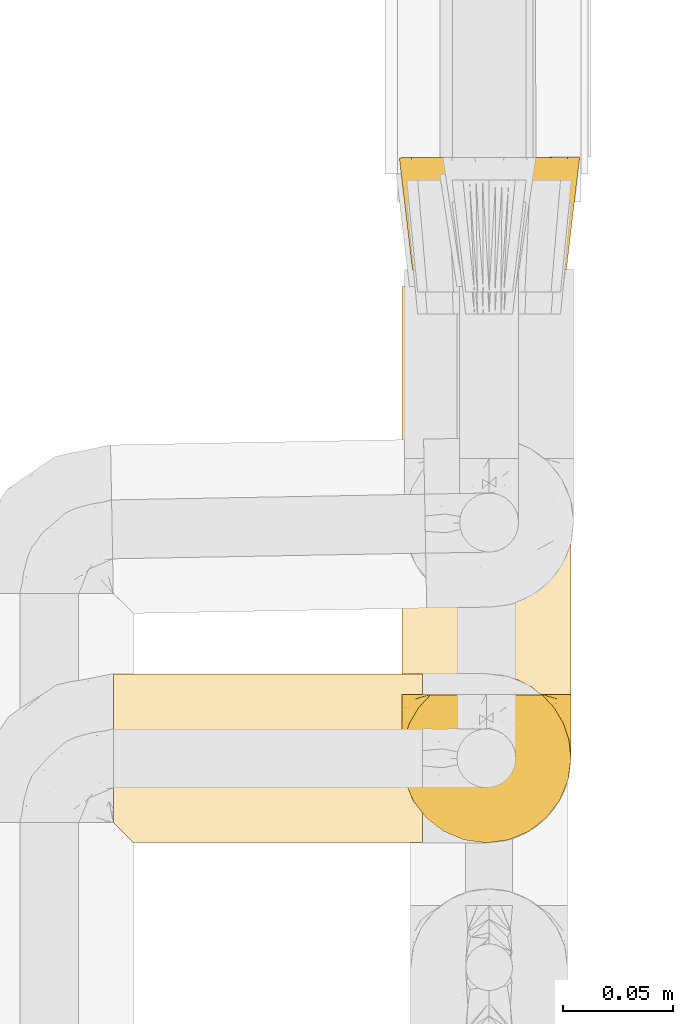
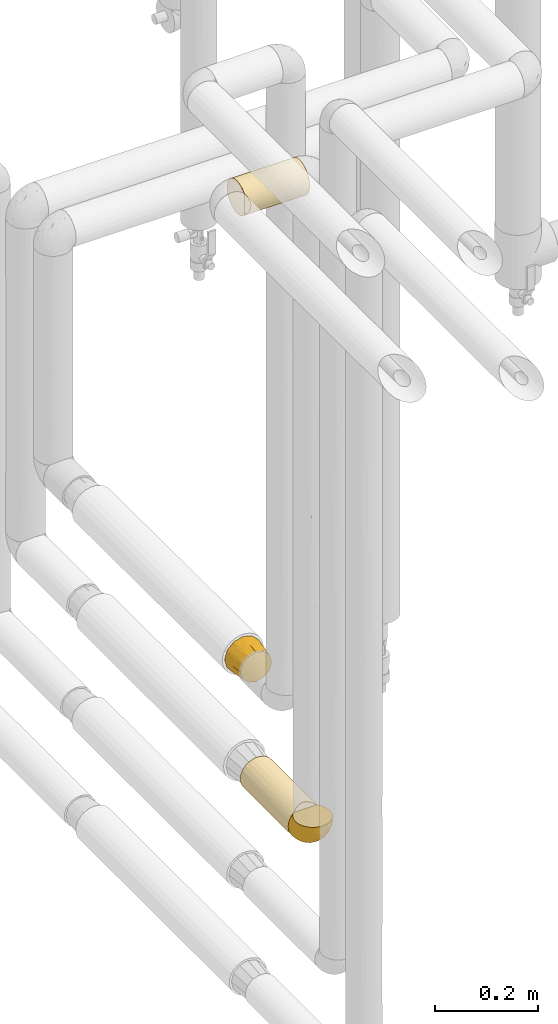
# One storey, part 72 of 827: 4 coverings.
"""IFC2X3 building model written with IfcOpenShell, lengths in millimetres."""

from ifc_helpers import new_model, entity, si_unit, converted_unit, derived_unit, direction, frame, origin, place, context, subcontext, project, spatial, faceted_brep, element, save


model = new_model("IFC2X3")

# Units and contexts
model_context = context("Model", 3, precision=0.01, world=origin(), true_north=direction((6.12303176911189e-17, 1.0)))
body_context = subcontext(model_context, "Body", "Model", "MODEL_VIEW")
ifc_project = project(units=[si_unit("LENGTHUNIT", "METRE", prefix="MILLI"), si_unit("AREAUNIT", "SQUARE_METRE"), si_unit("VOLUMEUNIT", "CUBIC_METRE"), converted_unit("PLANEANGLEUNIT", "DEGREE", entity("IfcRatioMeasure", 0.0174532925199433), si_unit("PLANEANGLEUNIT", "RADIAN"), dimensions=[0, 0, 0, 0, 0, 0, 0]), si_unit("MASSUNIT", "GRAM", prefix="KILO"), derived_unit("MASSDENSITYUNIT", [(si_unit("MASSUNIT", "GRAM", prefix="KILO"), 1), (si_unit("LENGTHUNIT", "METRE"), -3)]), derived_unit("MOMENTOFINERTIAUNIT", [(si_unit("LENGTHUNIT", "METRE"), 4)]), si_unit("TIMEUNIT", "SECOND"), si_unit("FREQUENCYUNIT", "HERTZ"), si_unit("THERMODYNAMICTEMPERATUREUNIT", "DEGREE_CELSIUS"), derived_unit("THERMALTRANSMITTANCEUNIT", [(si_unit("MASSUNIT", "GRAM", prefix="KILO"), 1), (si_unit("THERMODYNAMICTEMPERATUREUNIT", "KELVIN"), -1), (si_unit("TIMEUNIT", "SECOND"), -3)]), derived_unit("VOLUMETRICFLOWRATEUNIT", [(si_unit("LENGTHUNIT", "METRE"), 3), (si_unit("TIMEUNIT", "SECOND"), -1)]), derived_unit("MASSFLOWRATEUNIT", [(si_unit("MASSUNIT", "GRAM", prefix="KILO"), 1), (si_unit("TIMEUNIT", "SECOND"), -1)]), derived_unit("ROTATIONALFREQUENCYUNIT", [(si_unit("TIMEUNIT", "SECOND"), -1)]), si_unit("ELECTRICCURRENTUNIT", "AMPERE"), si_unit("ELECTRICVOLTAGEUNIT", "VOLT"), si_unit("POWERUNIT", "WATT"), si_unit("FORCEUNIT", "NEWTON", prefix="KILO"), si_unit("ILLUMINANCEUNIT", "LUX"), si_unit("LUMINOUSFLUXUNIT", "LUMEN"), si_unit("LUMINOUSINTENSITYUNIT", "CANDELA"), derived_unit("USERDEFINED", [(si_unit("MASSUNIT", "GRAM", prefix="KILO"), -1), (si_unit("LENGTHUNIT", "METRE"), -2), (si_unit("TIMEUNIT", "SECOND"), 3), (si_unit("LUMINOUSFLUXUNIT", "LUMEN"), 1)]), derived_unit("LINEARVELOCITYUNIT", [(si_unit("LENGTHUNIT", "METRE"), 1), (si_unit("TIMEUNIT", "SECOND"), -1)]), si_unit("PRESSUREUNIT", "PASCAL"), derived_unit("USERDEFINED", [(si_unit("LENGTHUNIT", "METRE"), -2), (si_unit("MASSUNIT", "GRAM", prefix="KILO"), 1), (si_unit("TIMEUNIT", "SECOND"), -2)]), derived_unit("LINEARFORCEUNIT", [(si_unit("MASSUNIT", "GRAM", prefix="KILO"), 1), (si_unit("LENGTHUNIT", "METRE"), 1), (si_unit("TIMEUNIT", "SECOND"), -2), (si_unit("LENGTHUNIT", "METRE"), -1)]), derived_unit("PLANARFORCEUNIT", [(si_unit("MASSUNIT", "GRAM", prefix="KILO"), 1), (si_unit("LENGTHUNIT", "METRE"), 1), (si_unit("TIMEUNIT", "SECOND"), -2), (si_unit("LENGTHUNIT", "METRE"), -2)])], contexts=[model_context])

# Site, building, storey
site_placement = place(None, origin())
site = spatial("IfcSite", under=ifc_project, at=site_placement, CompositionType="ELEMENT")
building_placement = place(site_placement, origin())
building = spatial("IfcBuilding", under=site, at=building_placement, CompositionType="ELEMENT")
storey_placement = place(building_placement, frame((0.0, 0.0, 28200.0)))
storey = spatial("IfcBuildingStorey", under=building, at=storey_placement, Name="08", CompositionType="ELEMENT", Elevation=28200.0)

# Coverings
covering_1_placement = place(storey_placement, frame((17886.09, 10978.31, 1305.65)))
element("IfcCovering", 1, at=covering_1_placement, inside=storey, Name=":ADSK_", ObjectType=":ADSK_", PredefinedType="INSULATION", context=body_context, shape_type="Brep", body=[
    faceted_brep([(9.95, 0.01, 51.35), (7.61, 0.0, 42.6), (9.95, 0.01, 33.85), (12.3, 0.02, 25.1), (18.7, 0.04, 18.69), (25.11, 0.06, 12.28), (33.86, 0.09, 9.94), (42.61, 0.12, 7.6), (51.36, 0.15, 9.94), (60.11, 0.18, 12.28), (66.51, 0.2, 18.69), (72.92, 0.22, 25.1), (75.26, 0.23, 33.85), (77.61, 0.24, 42.6), (75.26, 0.23, 51.35), (72.92, 0.22, 60.1), (66.51, 0.2, 66.5), (60.11, 0.18, 72.91), (51.36, 0.15, 75.25), (42.61, 0.12, 77.6), (33.86, 0.09, 75.25), (25.11, 0.06, 72.91), (18.7, 0.04, 66.5), (12.3, 0.02, 60.1), (63.09, 51.19, 78.1), (70.6, 51.21, 70.6), (78.1, 51.24, 63.1), (81.4, 51.25, 50.78), (83.59, 51.26, 42.6), (80.85, 51.25, 32.35), (78.1, 51.24, 22.1), (70.6, 51.21, 14.59), (63.09, 51.19, 7.09), (50.78, 51.15, 3.79), (42.6, 51.12, 1.6), (32.35, 51.08, 4.34), (22.1, 51.05, 7.09), (14.59, 51.02, 14.59), (7.09, 51.0, 22.1), (3.79, 50.99, 34.41), (1.6, 50.98, 42.6), (4.34, 50.99, 52.85), (7.09, 51.0, 63.1), (14.59, 51.02, 70.6), (22.1, 51.05, 78.1), (34.41, 51.09, 81.4), (42.6, 51.12, 83.6), (52.84, 51.15, 80.85), (7.49, 25.5, 28.05), (5.46, 24.36, 35.21), (11.28, 25.51, 21.08), (42.6, 23.62, 4.83), (19.47, 25.54, 12.45), (26.23, 25.56, 8.3), (4.84, 23.49, 42.6), (33.16, 25.59, 5.79), (57.14, 25.67, 7.49), (49.99, 24.51, 5.46), (64.11, 25.69, 11.27), (80.37, 23.76, 42.6), (72.75, 25.72, 19.46), (76.89, 25.74, 26.22), (79.41, 25.74, 33.15), (77.71, 25.74, 57.14), (79.74, 24.61, 49.98), (73.93, 25.73, 64.11), (42.6, 23.63, 80.36), (65.73, 25.7, 72.74), (58.97, 25.67, 76.89), (52.05, 25.65, 79.4), (28.06, 25.57, 77.7), (35.21, 24.46, 79.73), (21.09, 25.55, 73.92), (12.45, 25.52, 65.73), (8.31, 25.5, 58.97), (5.79, 25.49, 52.04)], [[[0, 1, 2, 3, 4, 5, 6, 7, 8, 9, 10, 11, 12, 13, 14, 15, 16, 17, 18, 19, 20, 21, 22, 23]], [[24, 25, 26, 27, 28, 29, 30, 31, 32, 33, 34, 35, 36, 37, 38, 39, 40, 41, 42, 43, 44, 45, 46, 47]], [[39, 48, 49]], [[49, 40, 39]], [[48, 39, 38]], [[3, 2, 48]], [[50, 3, 48]], [[48, 2, 49]], [[51, 7, 6]], [[52, 50, 37]], [[50, 48, 38]], [[5, 52, 53]], [[53, 52, 36]], [[37, 36, 52]], [[50, 38, 37]], [[54, 40, 49, 1]], [[52, 4, 50]], [[4, 3, 50]], [[4, 52, 5]], [[55, 6, 53]], [[53, 35, 55]], [[53, 36, 35]], [[1, 49, 2]], [[6, 5, 53]], [[34, 51, 55]], [[34, 55, 35]], [[51, 6, 55]], [[33, 56, 57]], [[57, 34, 33]], [[56, 33, 32]], [[9, 8, 56]], [[58, 9, 56]], [[56, 8, 57]], [[59, 13, 12]], [[60, 58, 31]], [[58, 56, 32]], [[11, 60, 61]], [[61, 60, 30]], [[31, 30, 60]], [[58, 32, 31]], [[51, 34, 57, 7]], [[60, 10, 58]], [[10, 9, 58]], [[10, 60, 11]], [[62, 12, 61]], [[61, 29, 62]], [[61, 30, 29]], [[7, 57, 8]], [[12, 11, 61]], [[28, 59, 62]], [[28, 62, 29]], [[59, 12, 62]], [[27, 63, 64]], [[64, 28, 27]], [[63, 27, 26]], [[15, 14, 63]], [[65, 15, 63]], [[63, 14, 64]], [[66, 19, 18]], [[67, 65, 25]], [[65, 63, 26]], [[17, 67, 68]], [[68, 67, 24]], [[25, 24, 67]], [[65, 26, 25]], [[59, 28, 64, 13]], [[67, 16, 65]], [[16, 15, 65]], [[16, 67, 17]], [[69, 18, 68]], [[68, 47, 69]], [[68, 24, 47]], [[13, 64, 14]], [[18, 17, 68]], [[46, 66, 69]], [[46, 69, 47]], [[66, 18, 69]], [[45, 70, 71]], [[71, 46, 45]], [[70, 45, 44]], [[21, 20, 70]], [[72, 21, 70]], [[70, 20, 71]], [[54, 1, 0]], [[73, 72, 43]], [[72, 70, 44]], [[23, 73, 74]], [[74, 73, 42]], [[43, 42, 73]], [[72, 44, 43]], [[66, 46, 71, 19]], [[73, 22, 72]], [[22, 21, 72]], [[22, 73, 23]], [[75, 0, 74]], [[74, 41, 75]], [[74, 42, 41]], [[19, 71, 20]], [[0, 23, 74]], [[40, 54, 75]], [[40, 75, 41]], [[54, 0, 75]]]),
])
covering_2_placement = place(storey_placement, frame((17887.28, 10782.63, 1062.52)))
element("IfcCovering", 2, at=covering_2_placement, inside=storey, Name=":ADSK_", ObjectType=":ADSK_", PredefinedType="INSULATION", context=body_context, shape_type="Brep", body=[
    faceted_brep([(20.8, 1.6, 6.74), (30.06, 1.6, 2.9), (40.0, 1.6, 1.6), (49.93, 1.6, 2.9), (59.2, 1.6, 6.74), (67.15, 1.6, 12.84), (73.25, 1.6, 20.8), (77.09, 1.6, 30.06), (78.4, 1.6, 40.0), (77.59, 1.6, 47.8), (75.23, 1.6, 55.25), (71.41, 1.6, 62.08), (66.27, 1.6, 68.0), (13.72, 1.6, 68.0), (8.58, 1.6, 62.08), (4.76, 1.6, 55.25), (2.4, 1.6, 47.8), (1.6, 1.6, 40.0), (2.9, 1.6, 30.06), (6.74, 1.6, 20.8), (12.84, 1.6, 12.84), (20.8, 188.22, 6.74), (12.84, 188.22, 12.84), (6.74, 188.22, 20.8), (2.9, 188.22, 30.06), (1.6, 188.22, 40.0), (2.9, 188.22, 49.93), (6.74, 188.22, 59.2), (12.84, 188.22, 67.15), (20.8, 188.22, 73.25), (30.06, 188.22, 77.09), (40.0, 188.22, 78.4), (49.93, 188.22, 77.09), (59.2, 188.22, 73.25), (67.15, 188.22, 67.15), (73.25, 188.22, 59.2), (77.09, 188.22, 49.93), (78.4, 188.22, 40.0), (77.09, 188.22, 30.06), (73.25, 188.22, 20.8), (67.15, 188.22, 12.84), (59.2, 188.22, 6.74), (49.93, 188.22, 2.9), (40.0, 188.22, 1.6), (30.06, 188.22, 2.9), (54.13, 9.3, 75.7), (47.19, 11.32, 77.72), (40.0, 12.0, 78.4), (60.56, 6.02, 72.42), (32.8, 11.32, 77.72), (25.86, 9.3, 75.7), (19.43, 6.02, 72.42)], [[[0, 1, 2, 3, 4, 5, 6, 7, 8, 9, 10, 11, 12, 13, 14, 15, 16, 17, 18, 19, 20]], [[21, 22, 23, 24, 25, 26, 27, 28, 29, 30, 31, 32, 33, 34, 35, 36, 37, 38, 39, 40, 41, 42, 43, 44]], [[24, 23, 19, 18]], [[25, 24, 18, 17]], [[23, 22, 20, 19]], [[1, 0, 21, 44]], [[2, 1, 44, 43]], [[22, 21, 0, 20]], [[3, 2, 43, 42]], [[4, 3, 42, 41]], [[41, 40, 5, 4]], [[7, 6, 39, 38]], [[8, 7, 38, 37]], [[40, 39, 6, 5]], [[9, 37, 36]], [[10, 36, 35]], [[11, 35, 34]], [[8, 37, 9]], [[9, 36, 10]], [[35, 11, 10]], [[34, 12, 11]], [[45, 33, 32]], [[32, 31, 46]], [[47, 46, 31]], [[12, 34, 48]], [[46, 45, 32]], [[48, 33, 45]], [[48, 34, 33]], [[49, 47, 31]], [[49, 31, 30]], [[50, 30, 29]], [[50, 49, 30]], [[28, 13, 51]], [[50, 29, 51]], [[51, 29, 28]], [[14, 28, 27]], [[15, 27, 26]], [[16, 26, 25]], [[14, 27, 15]], [[15, 26, 16]], [[25, 17, 16]], [[28, 14, 13]], [[45, 46, 47, 49, 50, 51, 13, 12, 48]]]),
])
covering_3_placement = place(storey_placement, frame((17887.23, 10716.18, 1062.47)))
element("IfcCovering", 3, at=covering_3_placement, inside=storey, Name=":ADSK_", ObjectType=":ADSK_", PredefinedType="INSULATION", context=body_context, shape_type="Brep", body=[
    faceted_brep([(74.68, 69.15, 23.36), (70.1, 69.15, 16.07), (64.01, 69.15, 9.98), (56.72, 69.15, 5.4), (48.6, 69.15, 2.56), (40.05, 69.15, 1.6), (31.49, 69.15, 2.56), (23.36, 69.15, 5.41), (16.07, 69.15, 9.99), (9.98, 69.15, 16.08), (5.4, 69.15, 23.37), (2.56, 69.15, 31.49), (1.6, 69.15, 40.05), (2.46, 69.15, 48.15), (5.01, 69.15, 55.88), (9.13, 69.15, 62.9), (14.62, 69.15, 68.89), (16.82, 69.15, 68.89), (18.56, 69.15, 68.89), (20.52, 69.15, 68.89), (22.49, 69.15, 68.89), (24.46, 69.15, 68.89), (26.42, 69.15, 68.89), (28.39, 69.15, 68.89), (30.36, 69.15, 68.89), (32.55, 69.15, 68.89), (34.75, 69.15, 68.89), (36.94, 69.15, 68.89), (39.13, 69.15, 68.89), (41.33, 69.15, 68.89), (43.52, 69.15, 68.89), (45.72, 69.15, 68.89), (47.91, 69.15, 68.89), (50.11, 69.15, 68.89), (52.3, 69.15, 68.89), (54.49, 69.15, 68.89), (56.69, 69.15, 68.89), (58.88, 69.15, 68.89), (61.08, 69.15, 68.89), (63.27, 69.15, 68.89), (65.47, 69.15, 68.89), (70.97, 69.15, 62.89), (75.09, 69.15, 55.86), (77.64, 69.15, 48.13), (78.5, 69.15, 40.05), (77.53, 69.15, 31.49), (14.62, 68.89, 69.15), (9.12, 62.89, 69.15), (5.0, 55.87, 69.15), (2.46, 48.14, 69.15), (1.6, 40.05, 69.15), (2.91, 30.09, 69.15), (6.75, 20.82, 69.15), (12.86, 12.86, 69.15), (20.82, 6.75, 69.15), (30.09, 2.91, 69.15), (40.05, 1.6, 69.15), (50.0, 2.91, 69.15), (59.27, 6.75, 69.15), (67.23, 12.86, 69.15), (73.34, 20.82, 69.15), (77.19, 30.09, 69.15), (78.5, 40.05, 69.15), (77.63, 48.14, 69.15), (75.09, 55.87, 69.15), (70.97, 62.89, 69.15), (65.47, 68.89, 69.15), (63.27, 68.89, 69.15), (62.29, 68.89, 69.15), (60.7, 68.89, 69.15), (59.11, 68.89, 69.15), (57.52, 68.89, 69.15), (55.93, 68.89, 69.15), (54.34, 68.89, 69.15), (52.76, 68.89, 69.15), (51.17, 68.89, 69.15), (49.58, 68.89, 69.15), (47.99, 68.89, 69.15), (46.4, 68.89, 69.15), (44.81, 68.89, 69.15), (43.22, 68.89, 69.15), (41.63, 68.89, 69.15), (40.05, 68.89, 69.15), (38.46, 68.89, 69.15), (36.87, 68.89, 69.15), (35.28, 68.89, 69.15), (33.69, 68.89, 69.15), (32.1, 68.89, 69.15), (30.51, 68.89, 69.15), (28.92, 68.89, 69.15), (27.33, 68.89, 69.15), (25.37, 68.89, 69.15), (23.4, 68.89, 69.15), (21.21, 68.89, 69.15), (19.01, 68.89, 69.15), (16.82, 68.89, 69.15), (42.32, 68.97, 68.96), (44.02, 68.96, 68.97), (47.13, 68.97, 68.97), (48.74, 68.97, 68.97), (23.57, 68.98, 68.95), (25.13, 68.97, 68.96), (61.34, 68.96, 68.98), (22.02, 68.96, 68.97), (29.72, 68.96, 68.97), (56.73, 68.96, 68.98), (55.14, 68.96, 68.97), (37.66, 68.96, 68.97), (64.12, 69.0, 68.94), (28.13, 68.96, 68.98), (26.62, 68.96, 68.98), (31.46, 68.97, 68.96), (16.16, 68.96, 68.97), (39.16, 68.96, 68.98), (50.37, 68.96, 68.98), (17.69, 68.97, 68.97), (19.17, 68.97, 68.96), (62.78, 68.97, 68.97), (58.35, 68.96, 68.97), (45.53, 68.96, 68.98), (59.91, 68.97, 68.96), (65.47, 68.97, 68.97), (65.47, 69.02, 68.94), (65.47, 69.08, 68.92), (14.62, 68.97, 68.97), (14.62, 68.94, 69.02), (14.62, 68.92, 69.08), (20.59, 68.96, 68.98), (32.99, 68.96, 68.97), (34.48, 68.95, 68.98), (51.91, 68.96, 68.97), (65.47, 68.92, 69.08), (65.47, 68.94, 69.02), (53.48, 68.98, 68.96), (14.62, 69.08, 68.92), (14.62, 69.02, 68.94), (40.77, 68.96, 68.97), (35.97, 68.97, 68.96), (7.84, 61.33, 67.02), (3.53, 53.1, 63.33), (8.32, 63.33, 64.61), (2.19, 55.53, 51.4), (3.53, 63.33, 53.1), (1.6, 54.6, 43.94), (1.6, 41.99, 61.87), (4.57, 57.07, 61.54), (3.96, 57.95, 57.95), (2.28, 51.56, 56.12), (1.6, 41.58, 63.4), (7.69, 61.7, 65.41), (8.32, 65.0, 63.04), (7.84, 67.02, 61.33), (1.6, 61.87, 41.99), (1.6, 49.27, 49.27), (1.6, 43.94, 54.6), (4.34, 61.21, 56.6), (1.6, 63.4, 41.58), (29.63, 33.11, 13.72), (27.34, 52.82, 5.82), (40.05, 43.3, 6.74), (2.39, 33.73, 58.82), (2.43, 36.52, 51.58), (9.07, 24.87, 42.09), (16.64, 14.17, 46.12), (9.54, 18.43, 55.56), (4.52, 28.67, 52.38), (4.52, 26.0, 61.54), (7.49, 49.25, 23.76), (7.49, 59.72, 20.5), (12.85, 55.1, 14.64), (2.35, 44.72, 41.77), (22.66, 34.15, 16.28), (32.9, 5.25, 49.4), (25.33, 6.75, 52.34), (40.05, 55.54, 4.3), (16.64, 10.47, 58.67), (19.99, 25.49, 25.26), (16.37, 35.53, 20.17), (3.26, 48.22, 34.7), (3.75, 58.71, 28.67), (19.58, 57.42, 8.62), (7.5, 34.84, 33.37), (4.04, 36.87, 41.35), (13.94, 45.01, 17.15), (19.58, 44.4, 12.68), (28.21, 23.96, 21.47), (24.75, 11.2, 41.11), (31.42, 10.56, 37.53), (26.2, 16.81, 30.64), (33.36, 17.38, 26.66), (40.05, 21.38, 21.38), (40.05, 32.34, 14.06), (40.05, 4.3, 55.54), (16.14, 20.65, 35.17), (12.85, 29.66, 29.04), (10.47, 39.6, 24.34), (6.49, 42.55, 29.33), (40.05, 6.74, 43.3), (40.05, 14.06, 32.34), (75.57, 26.84, 57.75), (47.37, 5.28, 49.41), (52.91, 18.52, 27.85), (50.46, 33.13, 13.7), (67.23, 55.1, 14.63), (60.5, 57.43, 8.61), (70.55, 20.72, 48.85), (63.45, 11.46, 54.13), (62.61, 17.69, 37.84), (72.6, 49.26, 23.75), (72.6, 59.73, 20.49), (76.34, 58.71, 28.66), (59.34, 29.72, 20.83), (77.76, 35.35, 55.15), (78.5, 43.94, 54.6), (78.5, 41.99, 61.87), (78.5, 63.4, 41.58), (53.16, 4.93, 57.58), (70.55, 17.46, 59.91), (48.88, 10.94, 36.94), (54.76, 8.92, 45.72), (52.74, 52.83, 5.82), (71.93, 29.34, 37.91), (75.79, 30.26, 50.18), (60.5, 44.4, 12.67), (77.86, 39.06, 49.29), (77.64, 43.06, 42.64), (78.5, 54.6, 43.94), (78.5, 49.27, 49.27), (67.23, 42.69, 19.45), (76.82, 48.2, 34.7), (78.5, 61.87, 41.99), (77.8, 33.44, 62.29), (67.23, 29.67, 29.01), (73.2, 38.5, 31.47), (67.66, 23.35, 37.18), (75.99, 34.97, 43.45), (76.57, 53.1, 63.33), (73.21, 59.68, 67.23), (71.93, 62.19, 66.07), (71.07, 64.11, 65.22), (75.09, 57.97, 61.99), (76.13, 57.95, 57.95), (76.57, 63.33, 53.09), (77.69, 51.77, 56.84), (72.26, 67.02, 61.33), (71.77, 64.98, 63.06), (77.9, 55.53, 51.41), (75.75, 61.22, 56.61)], [[[0, 1, 2, 3, 4, 5, 6, 7, 8, 9, 10, 11, 12, 13, 14, 15, 16, 17, 18, 19, 20, 21, 22, 23, 24, 25, 26, 27, 28, 29, 30, 31, 32, 33, 34, 35, 36, 37, 38, 39, 40, 41, 42, 43, 44, 45]], [[46, 47, 48, 49, 50, 51, 52, 53, 54, 55, 56, 57, 58, 59, 60, 61, 62, 63, 64, 65, 66, 67, 68, 69, 70, 71, 72, 73, 74, 75, 76, 77, 78, 79, 80, 81, 82, 83, 84, 85, 86, 87, 88, 89, 90, 91, 92, 93, 94, 95]], [[96, 97, 30]], [[98, 77, 99]], [[100, 101, 21]], [[69, 68, 102]], [[20, 19, 103]], [[24, 23, 104]], [[20, 103, 100]], [[72, 105, 106]], [[84, 83, 107]], [[89, 88, 104]], [[108, 67, 66]], [[109, 110, 90]], [[111, 25, 24]], [[112, 17, 16]], [[82, 113, 83]], [[109, 23, 22]], [[114, 76, 75]], [[105, 36, 106]], [[104, 111, 24]], [[18, 115, 116]], [[97, 96, 80]], [[67, 108, 117]], [[105, 71, 118]], [[31, 97, 119]], [[102, 120, 69]], [[108, 121, 122, 123, 40]], [[112, 95, 115]], [[17, 115, 18]], [[94, 116, 115]], [[117, 68, 67]], [[38, 117, 39]], [[112, 124, 125, 126, 46]], [[17, 112, 115]], [[70, 120, 118]], [[39, 117, 108]], [[120, 38, 37]], [[120, 37, 118]], [[120, 70, 69]], [[116, 94, 127]], [[128, 86, 129]], [[117, 38, 102]], [[74, 130, 75]], [[99, 33, 32]], [[115, 95, 94]], [[39, 108, 40]], [[108, 66, 131, 132, 121]], [[105, 72, 71]], [[118, 37, 36]], [[71, 70, 118]], [[35, 106, 36]], [[36, 105, 118]], [[35, 133, 106]], [[74, 73, 133]], [[106, 133, 73]], [[99, 114, 33]], [[133, 35, 34]], [[73, 72, 106]], [[95, 112, 46]], [[112, 16, 134, 135, 124]], [[130, 114, 75]], [[99, 76, 114]], [[114, 130, 33]], [[34, 33, 130]], [[78, 77, 98]], [[98, 119, 78]], [[130, 133, 34]], [[133, 130, 74]], [[79, 97, 80]], [[98, 99, 32]], [[98, 32, 31]], [[77, 76, 99]], [[97, 79, 119]], [[136, 96, 29]], [[30, 97, 31]], [[136, 29, 28]], [[81, 80, 96]], [[29, 96, 30]], [[31, 119, 98]], [[119, 79, 78]], [[96, 136, 81]], [[82, 81, 136]], [[113, 107, 83]], [[84, 107, 137]], [[107, 27, 137]], [[113, 28, 107]], [[27, 107, 28]], [[85, 84, 137]], [[137, 27, 26]], [[113, 136, 28]], [[136, 113, 82]], [[109, 89, 104]], [[86, 85, 129]], [[89, 109, 90]], [[111, 87, 128]], [[26, 129, 137]], [[88, 111, 104]], [[25, 111, 128]], [[22, 110, 109]], [[23, 109, 104]], [[110, 91, 90]], [[100, 92, 101]], [[110, 22, 101]], [[91, 110, 101]], [[116, 19, 18]], [[111, 88, 87]], [[127, 103, 19]], [[25, 128, 26]], [[86, 128, 87]], [[128, 129, 26]], [[137, 129, 85]], [[120, 102, 38]], [[117, 102, 68]], [[91, 101, 92]], [[21, 101, 22]], [[93, 92, 103]], [[100, 21, 20]], [[100, 103, 92]], [[127, 93, 103]], [[93, 127, 94]], [[116, 127, 19]], [[126, 138, 47]], [[48, 138, 139]], [[140, 125, 124]], [[141, 142, 143]], [[144, 49, 139]], [[145, 140, 146]], [[48, 139, 49]], [[139, 145, 147]], [[49, 144, 148, 50]], [[126, 125, 149]], [[14, 13, 142]], [[150, 146, 140]], [[149, 140, 145]], [[151, 150, 135]], [[151, 14, 142]], [[16, 15, 134]], [[13, 152, 142]], [[124, 150, 140]], [[141, 143, 153]], [[14, 151, 15]], [[15, 151, 134]], [[47, 46, 126]], [[139, 154, 144]], [[138, 48, 47]], [[125, 140, 149]], [[135, 134, 151]], [[146, 155, 141]], [[145, 146, 147]], [[149, 139, 138]], [[147, 153, 154]], [[147, 146, 141]], [[139, 147, 154]], [[139, 149, 145]], [[149, 138, 126]], [[147, 141, 153]], [[146, 150, 155]], [[151, 155, 150]], [[142, 141, 155]], [[13, 12, 156, 152]], [[152, 143, 142]], [[151, 142, 155]], [[150, 124, 135]], [[157, 158, 159]], [[160, 154, 161]], [[162, 163, 164]], [[165, 166, 160]], [[167, 168, 169]], [[153, 170, 161]], [[156, 12, 11]], [[158, 157, 171]], [[172, 55, 173]], [[158, 6, 174]], [[175, 54, 53]], [[52, 166, 164]], [[52, 164, 53]], [[54, 175, 173]], [[166, 52, 51]], [[176, 177, 171]], [[178, 143, 179]], [[156, 11, 179]], [[8, 7, 180]], [[169, 9, 8]], [[179, 143, 152, 156]], [[179, 11, 10]], [[168, 179, 10]], [[181, 162, 182]], [[179, 167, 178]], [[183, 184, 177]], [[183, 169, 184]], [[176, 171, 185]], [[172, 186, 187]], [[158, 7, 6]], [[159, 158, 174]], [[184, 180, 158]], [[54, 173, 55]], [[180, 169, 8]], [[188, 189, 187]], [[9, 168, 10]], [[186, 188, 187]], [[190, 157, 159, 191]], [[55, 172, 192]], [[176, 193, 194]], [[161, 170, 182]], [[162, 164, 165]], [[175, 164, 163]], [[51, 50, 148]], [[167, 195, 196]], [[178, 182, 170]], [[6, 5, 174]], [[158, 180, 7]], [[169, 180, 184]], [[169, 168, 9]], [[179, 168, 167]], [[182, 162, 165]], [[162, 194, 193]], [[161, 165, 160]], [[195, 181, 196]], [[192, 172, 197]], [[192, 56, 55]], [[189, 190, 198]], [[198, 197, 187]], [[172, 187, 197]], [[185, 189, 188]], [[198, 187, 189]], [[186, 172, 173]], [[173, 163, 186]], [[193, 186, 163]], [[176, 185, 188]], [[185, 157, 190]], [[188, 186, 193]], [[177, 176, 194]], [[188, 193, 176]], [[162, 193, 163]], [[195, 177, 194]], [[171, 177, 184]], [[181, 195, 194]], [[183, 167, 169]], [[162, 181, 194]], [[196, 182, 178]], [[158, 171, 184]], [[171, 157, 185]], [[177, 195, 183]], [[167, 183, 195]], [[182, 196, 181]], [[178, 170, 143]], [[178, 167, 196]], [[164, 175, 53]], [[173, 175, 163]], [[160, 51, 148]], [[164, 166, 165]], [[51, 160, 166]], [[160, 148, 144, 154]], [[153, 161, 154]], [[182, 165, 161]], [[190, 189, 185]], [[143, 170, 153]], [[60, 199, 61]], [[197, 200, 192]], [[201, 190, 202]], [[200, 57, 192]], [[203, 204, 2]], [[205, 206, 207]], [[208, 209, 210]], [[211, 207, 201]], [[212, 213, 214]], [[45, 215, 210]], [[216, 206, 58]], [[45, 44, 215]], [[59, 217, 60]], [[60, 217, 199]], [[0, 45, 210]], [[218, 201, 219]], [[202, 159, 220]], [[205, 221, 222]], [[223, 204, 203]], [[1, 203, 2]], [[57, 200, 216]], [[220, 3, 204]], [[220, 174, 4]], [[1, 0, 209]], [[212, 224, 213]], [[225, 226, 227]], [[228, 223, 203]], [[208, 210, 229]], [[210, 226, 229]], [[3, 220, 4]], [[58, 206, 59]], [[209, 203, 1]], [[202, 220, 223]], [[228, 203, 208]], [[202, 211, 201]], [[3, 2, 204]], [[202, 190, 191, 159]], [[210, 215, 230, 226]], [[199, 212, 231]], [[232, 233, 221]], [[233, 208, 229]], [[207, 206, 219]], [[217, 206, 205]], [[227, 224, 225]], [[233, 232, 228]], [[201, 207, 219]], [[234, 232, 221]], [[218, 219, 200]], [[202, 223, 211]], [[174, 220, 159]], [[174, 5, 4]], [[61, 231, 62]], [[220, 204, 223]], [[210, 209, 0]], [[203, 209, 208]], [[225, 233, 229]], [[224, 227, 213]], [[221, 233, 235]], [[57, 56, 192]], [[198, 218, 197]], [[200, 219, 216]], [[201, 198, 190]], [[197, 218, 200]], [[198, 201, 218]], [[206, 216, 219]], [[58, 57, 216]], [[231, 212, 214]], [[222, 212, 199]], [[228, 211, 223]], [[207, 211, 232]], [[62, 231, 214]], [[199, 231, 61]], [[233, 228, 208]], [[211, 228, 232]], [[222, 221, 235]], [[234, 205, 207]], [[206, 217, 59]], [[199, 217, 205]], [[205, 222, 199]], [[224, 222, 235]], [[222, 224, 212]], [[224, 235, 225]], [[233, 225, 235]], [[226, 225, 229]], [[205, 234, 221]], [[207, 232, 234]], [[63, 214, 236]], [[214, 213, 236]], [[214, 63, 62]], [[237, 236, 238]], [[238, 132, 131]], [[236, 237, 64]], [[239, 240, 241]], [[63, 236, 64]], [[131, 66, 65]], [[237, 131, 65]], [[242, 230, 43]], [[237, 65, 64]], [[239, 121, 132]], [[42, 242, 43]], [[241, 240, 243]], [[41, 123, 244]], [[43, 230, 215, 44]], [[244, 122, 245]], [[227, 246, 243]], [[241, 247, 245]], [[121, 239, 245]], [[41, 40, 123]], [[132, 238, 239]], [[244, 42, 41]], [[131, 237, 238]], [[240, 239, 238]], [[245, 239, 241]], [[247, 241, 246]], [[247, 244, 245]], [[238, 236, 240]], [[243, 236, 213]], [[236, 243, 240]], [[227, 226, 246]], [[243, 213, 227]], [[242, 246, 226]], [[243, 246, 241]], [[246, 242, 247]], [[244, 247, 242]], [[242, 226, 230]], [[42, 244, 242]], [[122, 244, 123]], [[122, 121, 245]]]),
])
covering_4_placement = place(storey_placement, frame((17756.03, 10716.23, 2611.73)))
element("IfcCovering", 4, at=covering_4_placement, inside=storey, Name=":ADSK_", ObjectType=":ADSK_", PredefinedType="INSULATION", context=body_context, shape_type="Brep", body=[
    faceted_brep([(142.15, 77.51, 31.79), (142.15, 78.4, 40.0), (142.15, 77.09, 49.93), (142.15, 73.25, 59.2), (142.15, 67.15, 67.15), (142.15, 59.2, 73.25), (142.15, 49.93, 77.09), (142.15, 40.0, 78.4), (142.15, 30.06, 77.09), (142.15, 20.8, 73.25), (142.15, 12.84, 67.15), (142.15, 6.74, 59.2), (142.15, 2.9, 49.93), (142.15, 1.6, 40.0), (142.15, 2.48, 31.79), (142.15, 5.09, 23.98), (142.15, 9.31, 16.91), (142.15, 14.94, 10.9), (142.15, 65.05, 10.9), (142.15, 70.68, 16.91), (142.15, 74.9, 23.98), (1.6, 31.79, 2.48), (1.6, 23.98, 5.09), (1.6, 16.91, 9.31), (1.6, 10.9, 14.94), (1.6, 10.9, 65.05), (1.6, 16.91, 70.68), (1.6, 23.98, 74.9), (1.6, 31.79, 77.51), (1.6, 40.0, 78.4), (1.6, 49.93, 77.09), (1.6, 59.2, 73.25), (1.6, 67.15, 67.15), (1.6, 73.25, 59.2), (1.6, 77.09, 49.93), (1.6, 78.4, 40.0), (1.6, 77.09, 30.06), (1.6, 73.25, 20.8), (1.6, 67.15, 12.84), (1.6, 59.2, 6.74), (1.6, 49.93, 2.9), (1.6, 40.0, 1.6), (10.29, 2.2, 33.21), (8.5, 4.0, 26.63), (5.57, 6.92, 20.48), (10.9, 1.6, 40.0), (138.17, 20.48, 6.92), (135.25, 26.63, 4.0), (133.45, 33.21, 2.2), (132.85, 40.0, 1.6), (133.45, 46.78, 2.2), (135.25, 53.36, 4.0), (138.17, 59.51, 6.92), (5.57, 6.92, 59.51), (8.5, 4.0, 53.36), (10.29, 2.2, 46.78)], [[[0, 1, 2, 3, 4, 5, 6, 7, 8, 9, 10, 11, 12, 13, 14, 15, 16, 17, 18, 19, 20]], [[21, 22, 23, 24, 25, 26, 27, 28, 29, 30, 31, 32, 33, 34, 35, 36, 37, 38, 39, 40, 41]], [[42, 43, 14]], [[44, 24, 16]], [[43, 44, 15]], [[45, 42, 13]], [[14, 13, 42]], [[43, 15, 14]], [[44, 16, 15]], [[24, 17, 16]], [[46, 23, 22]], [[47, 22, 21]], [[48, 21, 41]], [[46, 17, 23]], [[48, 47, 21]], [[49, 48, 41]], [[46, 22, 47]], [[23, 17, 24]], [[50, 49, 41]], [[50, 41, 40]], [[51, 40, 39]], [[51, 50, 40]], [[18, 52, 39]], [[51, 39, 52]], [[39, 38, 18]], [[19, 38, 37]], [[20, 37, 36]], [[0, 36, 35]], [[19, 37, 20]], [[20, 36, 0]], [[35, 1, 0]], [[38, 19, 18]], [[2, 1, 35, 34]], [[3, 2, 34, 33]], [[33, 32, 4, 3]], [[6, 5, 31, 30]], [[7, 6, 30, 29]], [[32, 31, 5, 4]], [[7, 29, 28]], [[8, 28, 27]], [[9, 27, 26]], [[7, 28, 8]], [[8, 27, 9]], [[26, 10, 9]], [[26, 25, 10]], [[25, 53, 11]], [[54, 55, 12]], [[53, 54, 11]], [[11, 54, 12]], [[13, 12, 55]], [[45, 13, 55]], [[25, 11, 10]], [[49, 50, 51, 52, 18, 17, 46, 47, 48]], [[24, 44, 43, 42, 45, 55, 54, 53, 25]]]),
])

save(model, "model.ifc")
